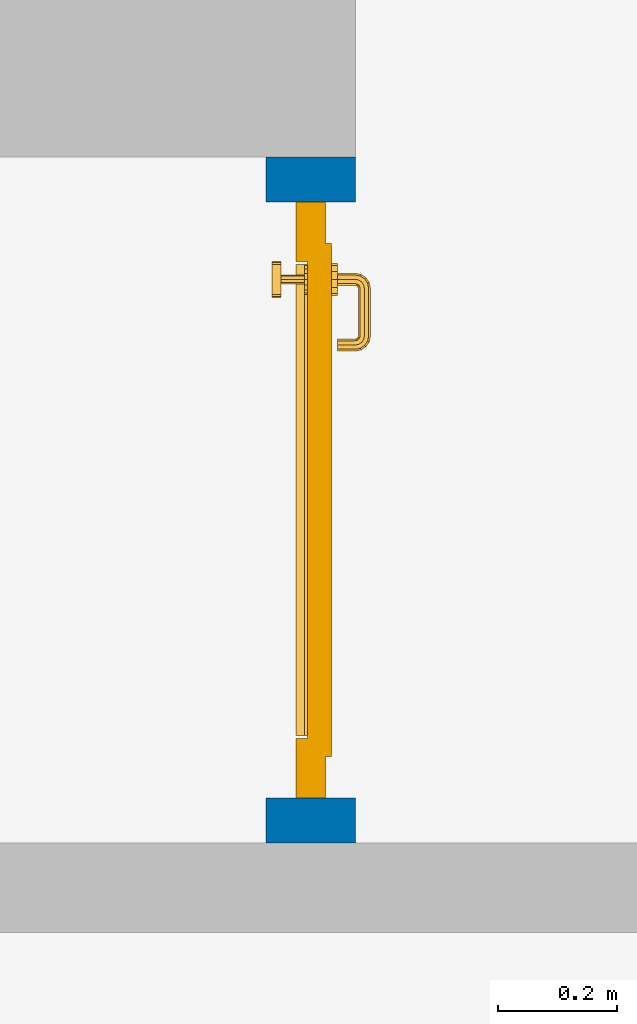
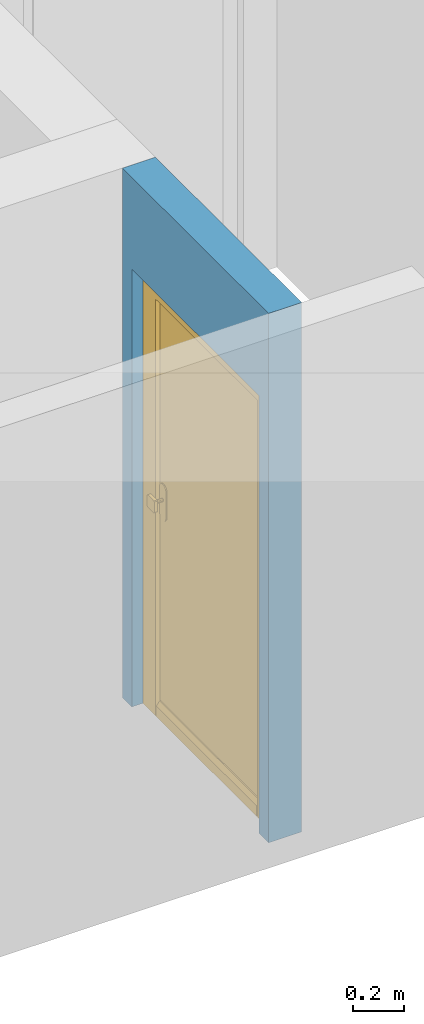
# One storey, part 4 of 54: 1 door, 1 wall, 1 opening.
"""IFC4 building model written with IfcOpenShell, lengths in metres."""

from ifc_helpers import new_model, entity, si_unit, converted_unit, derived_unit, direction, frame, origin_with_axes, place, context, subcontext, project, spatial, polygons, source, transform, mapped, material, type_object, element, fill, save


model = new_model("IFC4")

# Units and contexts
model_context = context("Model", 3, precision=1e-05, world=origin_with_axes(), true_north=direction((0.0, 1.0)))
body_context = subcontext(model_context, "Body", "Model", "MODEL_VIEW")
ifc_project = project(units=[si_unit("LENGTHUNIT", "METRE"), si_unit("AREAUNIT", "SQUARE_METRE"), si_unit("VOLUMEUNIT", "CUBIC_METRE"), converted_unit("PLANEANGLEUNIT", "DEGREE", entity("IfcPlaneAngleMeasure", 0.0174532925199), si_unit("PLANEANGLEUNIT", "RADIAN"), dimensions=[0, 0, 0, 0, 0, 0, 0]), converted_unit("TIMEUNIT", "Year", entity("IfcTimeMeasure", 31556926.0), si_unit("TIMEUNIT", "SECOND"), dimensions=[0, 0, 1, 0, 0, 0, 0]), si_unit("MASSUNIT", "GRAM", prefix="KILO"), si_unit("THERMODYNAMICTEMPERATUREUNIT", "DEGREE_CELSIUS"), si_unit("LUMINOUSINTENSITYUNIT", "LUMEN"), si_unit("ENERGYUNIT", "JOULE", prefix="MEGA"), derived_unit("THERMALCONDUCTANCEUNIT", [(si_unit("POWERUNIT", "WATT"), 1), (si_unit("LENGTHUNIT", "METRE"), -1), (si_unit("THERMODYNAMICTEMPERATUREUNIT", "KELVIN"), -1)]), derived_unit("SPECIFICHEATCAPACITYUNIT", [(si_unit("ENERGYUNIT", "JOULE"), 1), (si_unit("MASSUNIT", "GRAM", prefix="KILO"), -1), (si_unit("THERMODYNAMICTEMPERATUREUNIT", "KELVIN"), -1)]), derived_unit("MASSDENSITYUNIT", [(si_unit("MASSUNIT", "GRAM", prefix="KILO"), 1), (si_unit("VOLUMEUNIT", "CUBIC_METRE"), -1)])], contexts=[model_context])

# Site, building, storey
site_placement = place(None, origin_with_axes())
site = spatial("IfcSite", under=ifc_project, at=site_placement, CompositionType="ELEMENT")
building_placement = place(site_placement, origin_with_axes())
building = spatial("IfcBuilding", under=site, at=building_placement, CompositionType="ELEMENT")
storey_placement = place(building_placement, frame((0.0, 0.0, 9.18), z_axis=(0.0, 0.0, 1.0), x_axis=(1.0, 0.0, 0.0)))
storey = spatial("IfcBuildingStorey", under=building, at=storey_placement, Name="3. Geschoss", CompositionType="ELEMENT", Elevation=9.18)

# Wall, opening, door
ifc_material = material()
wall_type = type_object("IfcWallType", Name="150", PredefinedType="NOTDEFINED")
wall_placement = place(storey_placement, frame((2.8378006196, -4.12881223104, 0.0), z_axis=(0.0, 0.0, 1.0), x_axis=(0.0, 1.0, 0.0)))
wall = element("IfcWall", 1, at=wall_placement, inside=storey, type_object=wall_type, material=ifc_material, Name="Wand-002", PredefinedType="NOTDEFINED", context=body_context, shape_type="Tessellation", body=[
    polygons([(0.225, 0.0, 0.0), (0.225, 0.0, 2.1), (1.225, 0.0, 2.1), (1.225, 0.0, 0.0), (1.3, 0.0, 0.0), (1.3, 0.0, 2.54), (0.15, 0.0, 2.54), (0.15, 0.0, 0.0), (0.225, 0.1, 0.0), (0.225, 0.15, 0.0), (0.225, 0.15, 2.1), (1.225, 0.15, 2.1), (1.225, 0.1, 0.0), (1.225, 0.15, 0.0), (1.3, 0.15, 0.0), (1.3, 0.15, 2.54), (0.15, 0.15, 2.54), (0.15, 0.15, 0.0)], [[[1, 2, 3, 4, 5, 6, 7, 8]], [[2, 1, 9, 10, 11]], [[3, 2, 11, 12]], [[13, 4, 3, 12, 14]], [[4, 13, 14, 15, 5]], [[6, 5, 15, 16]], [[6, 16, 17, 7]], [[17, 18, 8, 7]], [[9, 1, 8, 18, 10]], [[15, 14, 12, 11, 10, 18, 17, 16]]], closed=True),
])
opening_placement = place(wall_placement, frame((0.725, 0.0, 0.0), z_axis=(0.0, 0.0, 1.0), x_axis=(1.0, 0.0, 0.0)))
opening = element("IfcOpeningElement", 2, at=opening_placement, cuts=wall, context=body_context, identifier="Reference", shape_type="Tessellation", body=[
    polygons([(-0.5, 0.1, 0.0), (-0.5, 0.1, 2.1), (-0.5, 0.151, 2.1), (-0.5, 0.151, 0.0), (-0.5, -0.001, 0.0), (-0.5, -0.001, 2.1), (0.5, 0.1, 2.1), (0.5, 0.151, 2.1), (0.5, -0.001, 2.1), (0.5, 0.151, 0.0), (0.5, 0.1, 0.0), (0.5, -0.001, 0.0)], [[[1, 2, 3, 4]], [[2, 1, 5, 6]], [[7, 8, 3, 2, 6, 9]], [[8, 10, 4, 3]], [[1, 4, 10, 11, 12, 5]], [[6, 5, 12, 9]], [[7, 11, 10, 8]], [[11, 7, 9, 12]]], closed=True),
])
door_type = type_object("IfcDoorType", Name="Eingang 01 1-Fl 26", OperationType="SINGLE_SWING_RIGHT", PredefinedType="DOOR")
shared_shape = source(origin_with_axes(), body_context, "Body", "Tessellation", [
    polygons([(0.5, -0.05, 0.0), (0.5, -0.03, 0.0), (0.5, -0.03, 2.1), (0.5, -0.05, 2.1), (0.4, -0.05, 0.0), (0.4, -0.03, 0.0), (0.4, -0.03, 2.0), (0.1301, -0.03, 2.0), (0.0001, -0.03, 2.0), (-0.4, -0.03, 2.0), (-0.4, -0.03, 0.0), (-0.5, -0.03, 0.0), (-0.5, -0.03, 2.1), (-0.5, -0.05, 2.1), (-0.5, -0.05, 0.0), (-0.4, -0.05, 0.0), (-0.4, -0.05, 2.0), (0.0001, -0.05, 2.0), (0.1301, -0.05, 2.0), (0.4, -0.05, 2.0)], [[[1, 2, 3, 4]], [[5, 6, 2, 1]], [[2, 6, 7, 8, 9, 10, 11, 12, 13, 3]], [[4, 3, 13, 14]], [[1, 4, 14, 15, 16, 17, 18, 19, 20, 5]], [[20, 7, 6, 5]], [[19, 8, 7, 20]], [[18, 9, 8, 19]], [[17, 10, 9, 18]], [[16, 11, 10, 17]], [[15, 12, 11, 16]], [[14, 13, 12, 15]]], closed=True),
    polygons([(0.5, -0.03, 0.0), (0.5, 0.0, 0.0), (0.5, 0.0, 2.1), (0.5, -0.03, 2.1), (0.43, -0.03, 0.0), (0.43, 0.0, 0.0), (0.43, 0.0, 2.03), (0.1001, 0.0, 2.03), (0.0301, 0.0, 2.03), (-0.43, 0.0, 2.03), (-0.43, 0.0, 0.0), (-0.5, 0.0, 0.0), (-0.5, 0.0, 2.1), (-0.5, -0.03, 2.1), (-0.5, -0.03, 0.0), (-0.43, -0.03, 0.0), (-0.43, -0.03, 2.03), (0.0301, -0.03, 2.03), (0.1001, -0.03, 2.03), (0.43, -0.03, 2.03)], [[[1, 2, 3, 4]], [[5, 6, 2, 1]], [[2, 6, 7, 8, 9, 10, 11, 12, 13, 3]], [[4, 3, 13, 14]], [[1, 4, 14, 15, 16, 17, 18, 19, 20, 5]], [[20, 7, 6, 5]], [[19, 8, 7, 20]], [[18, 9, 8, 19]], [[17, 10, 9, 18]], [[16, 11, 10, 17]], [[15, 12, 11, 16]], [[14, 13, 12, 15]]], closed=True),
    polygons([(0.43, 0.01, 0.0), (-0.43, 0.01, 0.0), (-0.43, 0.01, 2.03), (0.43, 0.01, 2.03), (0.43, -0.03, 0.0), (-0.43, -0.03, 0.0), (-0.43, -0.03, 2.03), (0.43, -0.03, 2.03)], [[[1, 2, 3, 4]], [[2, 1, 5, 6]], [[3, 2, 6, 7]], [[4, 3, 7, 8]], [[1, 4, 8, 5]], [[6, 5, 8, 7]]], closed=True),
    polygons([(0.395, -0.05, 0.0), (0.395, -0.05, 0.05), (-0.395, -0.05, 0.05), (-0.395, -0.05, 0.0), (0.395, -0.03, 0.0), (0.395, -0.03, 0.07), (0.395, -0.035, 0.07), (-0.395, -0.035, 0.07), (-0.395, -0.03, 0.07), (-0.395, -0.03, 0.0)], [[[1, 2, 3, 4]], [[1, 5, 6, 7, 2]], [[2, 7, 8, 3]], [[4, 3, 8, 9, 10]], [[5, 1, 4, 10]], [[6, 5, 10, 9]], [[7, 6, 9, 8]]], closed=True),
    polygons([(-0.3835, 0.02, 1.0733826859), (-0.3835, 0.0199, 1.0733826859), (-0.37, 0.0199, 1.077), (-0.37, 0.02, 1.077), (-0.393382685902, 0.02, 1.0635), (-0.393382685902, 0.0199, 1.0635), (-0.3835, 0.0101, 1.0733826859), (-0.37, 0.0101, 1.077), (-0.3565, 0.0199, 1.0733826859), (-0.3565, 0.02, 1.0733826859), (-0.346617314098, 0.02, 1.0635), (-0.343, 0.02, 1.05), (-0.346617314098, 0.02, 1.0365), (-0.3565, 0.02, 1.0266173141), (-0.37, 0.02, 1.023), (-0.3835, 0.02, 1.0266173141), (-0.393382685902, 0.02, 1.0365), (-0.397, 0.02, 1.05), (-0.397, 0.0199, 1.05), (-0.393382685902, 0.0101, 1.0635), (-0.3835, 0.01, 1.0733826859), (-0.37, 0.01, 1.077), (-0.3565, 0.0101, 1.0733826859), (-0.346617314098, 0.0199, 1.0635), (-0.343, 0.0199, 1.05), (-0.346617314098, 0.0199, 1.0365), (-0.3565, 0.0199, 1.0266173141), (-0.37, 0.0199, 1.023), (-0.3835, 0.0199, 1.0266173141), (-0.393382685902, 0.0199, 1.0365), (-0.397, 0.0101, 1.05), (-0.393382685902, 0.01, 1.0635), (-0.397, 0.01, 1.05), (-0.393382685902, 0.01, 1.0365), (-0.3835, 0.01, 1.0266173141), (-0.37, 0.01, 1.023), (-0.3565, 0.01, 1.0266173141), (-0.346617314098, 0.01, 1.0365), (-0.343, 0.01, 1.05), (-0.346617314098, 0.01, 1.0635), (-0.3565, 0.01, 1.0733826859), (-0.346617314098, 0.0101, 1.0635), (-0.343, 0.0101, 1.05), (-0.346617314098, 0.0101, 1.0365), (-0.3565, 0.0101, 1.0266173141), (-0.37, 0.0101, 1.023), (-0.3835, 0.0101, 1.0266173141), (-0.393382685902, 0.0101, 1.0365)], [[[1, 2, 3, 4]], [[5, 6, 2, 1]], [[2, 7, 8, 3]], [[4, 3, 9, 10]], [[4, 10, 11, 12, 13, 14, 15, 16, 17, 18, 5, 1]], [[18, 19, 6, 5]], [[6, 20, 7, 2]], [[7, 21, 22, 8]], [[3, 8, 23, 9]], [[10, 9, 24, 11]], [[11, 24, 25, 12]], [[12, 25, 26, 13]], [[13, 26, 27, 14]], [[14, 27, 28, 15]], [[15, 28, 29, 16]], [[16, 29, 30, 17]], [[17, 30, 19, 18]], [[19, 31, 20, 6]], [[20, 32, 21, 7]], [[22, 21, 32, 33, 34, 35, 36, 37, 38, 39, 40, 41]], [[8, 22, 41, 23]], [[9, 23, 42, 24]], [[24, 42, 43, 25]], [[25, 43, 44, 26]], [[26, 44, 45, 27]], [[27, 45, 46, 28]], [[28, 46, 47, 29]], [[29, 47, 48, 30]], [[30, 48, 31, 19]], [[31, 33, 32, 20]], [[48, 34, 33, 31]], [[47, 35, 34, 48]], [[46, 36, 35, 47]], [[45, 37, 36, 46]], [[44, 38, 37, 45]], [[43, 39, 38, 44]], [[42, 40, 39, 43]], [[23, 41, 40, 42]]], closed=True),
    polygons([(-0.362532169224, 0.019, 0.959692280177), (-0.365, 0.019, 0.9544), (-0.365, 0.019, 0.952886751346), (-0.347569942042, 0.019, 0.96295), (-0.35705, 0.019, 0.972430057958), (-0.363279754556, 0.019, 0.961639806549), (-0.362532169224, 0.02, 0.959692280177), (-0.365, 0.02, 0.9544), (-0.365, 0.02, 0.952886751346), (-0.365, 0.02, 0.95), (-0.365, 0.02, 0.947113248654), (-0.365, 0.02, 0.941339745962), (-0.365, 0.02, 0.9375), (-0.365, 0.019, 0.9375), (-0.365, 0.019, 0.941339745962), (-0.365, 0.019, 0.947113248654), (-0.365, 0.019, 0.95), (-0.3441, 0.019, 0.95), (-0.347483339502, 0.019, 0.963), (-0.357, 0.019, 0.972516660498), (-0.364624817685, 0.019, 0.965143815798), (-0.37, 0.019, 0.9759), (-0.37, 0.019, 0.967425445323), (-0.364624817685, 0.02, 0.965143815798), (-0.363279754556, 0.02, 0.961639806549), (-0.35655, 0.02, 0.973296083362), (-0.346703916638, 0.02, 0.96345), (-0.3431, 0.02, 0.95), (-0.346703916638, 0.02, 0.93655), (-0.35655, 0.02, 0.926703916638), (-0.37, 0.02, 0.9231), (-0.37, 0.02, 0.9325), (-0.366464466094, 0.02, 0.933964466094), (-0.366464466094, 0.019, 0.933964466094), (-0.35705, 0.019, 0.927569942042), (-0.37, 0.019, 0.9325), (-0.37, 0.019, 0.9241), (-0.347569942042, 0.019, 0.93705), (-0.344, 0.019, 0.95), (-0.347483339502, 0.0189, 0.963), (-0.357, 0.0189, 0.972516660498), (-0.37, 0.019, 0.976), (-0.375375182315, 0.019, 0.965143815798), (-0.38295, 0.019, 0.972430057958), (-0.376720245444, 0.019, 0.961639806549), (-0.37, 0.02, 0.967425445323), (-0.37, 0.02, 0.9769), (-0.346617314098, 0.02, 0.9635), (-0.3565, 0.02, 0.973382685902), (-0.343, 0.02, 0.95), (-0.346617314098, 0.02, 0.9365), (-0.3565, 0.02, 0.926617314098), (-0.38345, 0.02, 0.926703916638), (-0.375, 0.02, 0.941339745962), (-0.375, 0.02, 0.9375), (-0.373535533906, 0.02, 0.933964466094), (-0.37, 0.02, 0.923), (-0.373535533906, 0.019, 0.933964466094), (-0.375, 0.019, 0.9375), (-0.375, 0.019, 0.941339745962), (-0.38295, 0.019, 0.927569942042), (-0.37, 0.019, 0.924), (-0.357, 0.019, 0.927483339502), (-0.347483339502, 0.019, 0.937), (-0.344, 0.0189, 0.95), (-0.347483339502, 0.0101, 0.963), (-0.357, 0.0101, 0.972516660498), (-0.37, 0.0189, 0.976), (-0.383, 0.019, 0.972516660498), (-0.375375182315, 0.02, 0.965143815798), (-0.377467830776, 0.019, 0.959692280177), (-0.392430057958, 0.019, 0.96295), (-0.375, 0.019, 0.952886751346), (-0.375, 0.019, 0.9544), (-0.377467830776, 0.02, 0.959692280177), (-0.376720245444, 0.02, 0.961639806549), (-0.38345, 0.02, 0.973296083362), (-0.37, 0.02, 0.977), (-0.346617314098, 0.0199, 0.9635), (-0.3565, 0.0199, 0.973382685902), (-0.343, 0.0199, 0.95), (-0.346617314098, 0.0199, 0.9365), (-0.3565, 0.0199, 0.926617314098), (-0.393296083362, 0.02, 0.93655), (-0.375, 0.02, 0.947113248654), (-0.375, 0.02, 0.9544), (-0.375, 0.019, 0.95), (-0.375, 0.019, 0.947113248654), (-0.375, 0.02, 0.95), (-0.375, 0.02, 0.952886751346), (-0.3835, 0.02, 0.926617314098), (-0.37, 0.0199, 0.923), (-0.392430057958, 0.019, 0.93705), (-0.383, 0.019, 0.927483339502), (-0.37, 0.0189, 0.924), (-0.357, 0.0189, 0.927483339502), (-0.347483339502, 0.0189, 0.937), (-0.344, 0.0101, 0.95), (-0.347483339502, 0.01, 0.963), (-0.357, 0.01, 0.972516660498), (-0.37, 0.0101, 0.976), (-0.383, 0.0189, 0.972516660498), (-0.392516660498, 0.019, 0.963), (-0.3959, 0.019, 0.95), (-0.393296083362, 0.02, 0.96345), (-0.3835, 0.02, 0.973382685902), (-0.37, 0.0199, 0.977), (-0.346617314098, 0.0101, 0.9635), (-0.3565, 0.0101, 0.973382685902), (-0.343, 0.0101, 0.95), (-0.346617314098, 0.0101, 0.9365), (-0.3565, 0.0101, 0.926617314098), (-0.393382685902, 0.02, 0.9365), (-0.3969, 0.02, 0.95), (-0.3835, 0.0199, 0.926617314098), (-0.37, 0.0101, 0.923), (-0.392516660498, 0.019, 0.937), (-0.383, 0.0189, 0.927483339502), (-0.37, 0.0101, 0.924), (-0.357, 0.0101, 0.927483339502), (-0.347483339502, 0.0101, 0.937), (-0.344, 0.01, 0.95), (-0.347396736961, 0.01, 0.96305), (-0.35695, 0.01, 0.972603263039), (-0.37, 0.01, 0.976), (-0.383, 0.0101, 0.972516660498), (-0.392516660498, 0.0189, 0.963), (-0.396, 0.019, 0.95), (-0.393382685902, 0.02, 0.9635), (-0.3835, 0.0199, 0.973382685902), (-0.37, 0.0101, 0.977), (-0.346617314098, 0.01, 0.9635), (-0.3565, 0.01, 0.973382685902), (-0.343, 0.01, 0.95), (-0.346617314098, 0.01, 0.9365), (-0.3565, 0.01, 0.926617314098), (-0.397, 0.02, 0.95), (-0.393382685902, 0.0199, 0.9365), (-0.3835, 0.0101, 0.926617314098), (-0.37, 0.01, 0.923), (-0.392516660498, 0.0189, 0.937), (-0.383, 0.0101, 0.927483339502), (-0.37, 0.01, 0.924), (-0.357, 0.01, 0.927483339502), (-0.347483339502, 0.01, 0.937), (-0.3439, 0.01, 0.95), (-0.346703916638, 0.01, 0.96345), (-0.35655, 0.01, 0.973296083362), (-0.37, 0.01, 0.9761), (-0.383, 0.01, 0.972516660498), (-0.392516660498, 0.0101, 0.963), (-0.396, 0.0189, 0.95), (-0.393382685902, 0.0199, 0.9635), (-0.3835, 0.0101, 0.973382685902), (-0.37, 0.01, 0.977), (-0.3431, 0.01, 0.95), (-0.346703916638, 0.01, 0.93655), (-0.35655, 0.01, 0.926703916638), (-0.397, 0.0199, 0.95), (-0.393382685902, 0.0101, 0.9365), (-0.3835, 0.01, 0.926617314098), (-0.37, 0.01, 0.9231), (-0.392516660498, 0.0101, 0.937), (-0.383, 0.01, 0.927483339502), (-0.37, 0.01, 0.9239), (-0.35695, 0.01, 0.927396736961), (-0.347396736961, 0.01, 0.93695), (-0.37, 0.01, 0.9769), (-0.38305, 0.01, 0.972603263039), (-0.392516660498, 0.01, 0.963), (-0.396, 0.0101, 0.95), (-0.393382685902, 0.0101, 0.9635), (-0.3835, 0.01, 0.973382685902), (-0.397, 0.0101, 0.95), (-0.393382685902, 0.01, 0.9365), (-0.38345, 0.01, 0.926703916638), (-0.392516660498, 0.01, 0.937), (-0.38305, 0.01, 0.927396736961), (-0.38345, 0.01, 0.973296083362), (-0.392603263039, 0.01, 0.96305), (-0.396, 0.01, 0.95), (-0.393382685902, 0.01, 0.9635), (-0.397, 0.01, 0.95), (-0.393296083362, 0.01, 0.93655), (-0.392603263039, 0.01, 0.93695), (-0.393296083362, 0.01, 0.96345), (-0.3961, 0.01, 0.95), (-0.3969, 0.01, 0.95)], [[[1, 2, 3, 4, 5, 6]], [[2, 1, 7, 8]], [[2, 8, 9, 10, 11, 12, 13, 14, 15, 16, 17, 3]], [[17, 18, 4, 3]], [[4, 19, 20, 5]], [[21, 6, 5, 22, 23]], [[1, 6, 21, 24, 25, 7]], [[7, 25, 26, 27, 9, 8]], [[9, 27, 28, 10]], [[10, 28, 29, 11]], [[11, 29, 30, 12]], [[31, 32, 33, 13, 12, 30]], [[14, 13, 33, 34]], [[35, 15, 14, 34, 36, 37]], [[15, 35, 38, 16]], [[16, 38, 18, 17]], [[18, 39, 19, 4]], [[19, 40, 41, 20]], [[5, 20, 42, 22]], [[43, 23, 22, 44, 45]], [[21, 23, 46, 24]], [[24, 46, 47, 26, 25]], [[48, 27, 26, 49]], [[50, 28, 27, 48]], [[51, 29, 28, 50]], [[52, 30, 29, 51]], [[53, 54, 55, 56, 32, 31]], [[34, 33, 32, 36]], [[57, 31, 30, 52]], [[37, 36, 58, 59, 60, 61]], [[37, 62, 63, 35]], [[35, 63, 64, 38]], [[38, 64, 39, 18]], [[39, 65, 40, 19]], [[40, 66, 67, 41]], [[20, 41, 68, 42]], [[22, 42, 69, 44]], [[23, 43, 70, 46]], [[71, 45, 44, 72, 73, 74]], [[43, 45, 71, 75, 76, 70]], [[70, 76, 77, 47, 46]], [[49, 26, 47, 78]], [[79, 48, 49, 80]], [[81, 50, 48, 79]], [[82, 51, 50, 81]], [[83, 52, 51, 82]], [[54, 53, 84, 85]], [[86, 74, 73, 87, 88, 60, 59, 55, 54, 85, 89, 90]], [[58, 56, 55, 59]], [[36, 32, 56, 58]], [[91, 53, 31, 57]], [[92, 57, 52, 83]], [[88, 93, 61, 60]], [[61, 94, 62, 37]], [[62, 95, 96, 63]], [[63, 96, 97, 64]], [[64, 97, 65, 39]], [[65, 98, 66, 40]], [[66, 99, 100, 67]], [[41, 67, 101, 68]], [[42, 68, 102, 69]], [[44, 69, 103, 72]], [[73, 72, 104, 87]], [[71, 74, 86, 75]], [[75, 86, 90, 105, 77, 76]], [[78, 47, 77, 106]], [[80, 49, 78, 107]], [[108, 79, 80, 109]], [[110, 81, 79, 108]], [[111, 82, 81, 110]], [[112, 83, 82, 111]], [[113, 84, 53, 91]], [[85, 84, 114, 89]], [[87, 104, 93, 88]], [[89, 114, 105, 90]], [[115, 91, 57, 92]], [[116, 92, 83, 112]], [[93, 117, 94, 61]], [[94, 118, 95, 62]], [[95, 119, 120, 96]], [[96, 120, 121, 97]], [[97, 121, 98, 65]], [[98, 122, 99, 66]], [[99, 123, 124, 100]], [[67, 100, 125, 101]], [[68, 101, 126, 102]], [[69, 102, 127, 103]], [[72, 103, 128, 104]], [[106, 77, 105, 129]], [[107, 78, 106, 130]], [[109, 80, 107, 131]], [[132, 108, 109, 133]], [[134, 110, 108, 132]], [[135, 111, 110, 134]], [[136, 112, 111, 135]], [[137, 114, 84, 113]], [[138, 113, 91, 115]], [[104, 128, 117, 93]], [[129, 105, 114, 137]], [[139, 115, 92, 116]], [[140, 116, 112, 136]], [[117, 141, 118, 94]], [[118, 142, 119, 95]], [[119, 143, 144, 120]], [[120, 144, 145, 121]], [[121, 145, 122, 98]], [[122, 146, 123, 99]], [[123, 147, 148, 124]], [[100, 124, 149, 125]], [[101, 125, 150, 126]], [[102, 126, 151, 127]], [[103, 127, 152, 128]], [[130, 106, 129, 153]], [[131, 107, 130, 154]], [[133, 109, 131, 155]], [[147, 132, 133, 148]], [[156, 134, 132, 147]], [[157, 135, 134, 156]], [[158, 136, 135, 157]], [[159, 137, 113, 138]], [[160, 138, 115, 139]], [[128, 152, 141, 117]], [[153, 129, 137, 159]], [[161, 139, 116, 140]], [[162, 140, 136, 158]], [[141, 163, 142, 118]], [[142, 164, 143, 119]], [[143, 165, 166, 144]], [[144, 166, 167, 145]], [[145, 167, 146, 122]], [[146, 156, 147, 123]], [[124, 148, 168, 149]], [[125, 149, 169, 150]], [[126, 150, 170, 151]], [[127, 151, 171, 152]], [[154, 130, 153, 172]], [[155, 131, 154, 173]], [[148, 133, 155, 168]], [[167, 157, 156, 146]], [[166, 158, 157, 167]], [[174, 159, 138, 160]], [[175, 160, 139, 161]], [[152, 171, 163, 141]], [[172, 153, 159, 174]], [[176, 161, 140, 162]], [[165, 162, 158, 166]], [[163, 177, 164, 142]], [[164, 178, 165, 143]], [[149, 168, 179, 169]], [[150, 169, 180, 170]], [[151, 170, 181, 171]], [[173, 154, 172, 182]], [[168, 155, 173, 179]], [[183, 174, 160, 175]], [[184, 175, 161, 176]], [[171, 181, 177, 163]], [[182, 172, 174, 183]], [[178, 176, 162, 165]], [[177, 185, 178, 164]], [[169, 179, 186, 180]], [[170, 180, 187, 181]], [[179, 173, 182, 186]], [[188, 183, 175, 184]], [[185, 184, 176, 178]], [[181, 187, 185, 177]], [[186, 182, 183, 188]], [[180, 186, 188, 187]], [[187, 188, 184, 185]]], closed=True),
    polygons([(-0.38, 0.02, 1.05), (-0.38, 0.0509849140336, 1.05), (-0.377071067812, 0.050696439392, 1.04292893219), (-0.377071067812, 0.02, 1.04292893219), (-0.377071067812, 0.02, 1.05707106781), (-0.377071067812, 0.050696439392, 1.05707106781), (-0.378277987014, 0.0596420579258, 1.05), (-0.375518993221, 0.0584992452783, 1.04292893219), (-0.37, 0.05, 1.04), (-0.37, 0.02, 1.04), (-0.37, 0.02, 1.06), (-0.37, 0.05, 1.06), (-0.375518993221, 0.0584992452783, 1.05707106781), (-0.372816199938, 0.0678161999379, 1.05), (-0.370704557509, 0.0657045575088, 1.04292893219), (-0.368858192988, 0.0557402514855, 1.04), (-0.362928932188, 0.049303560608, 1.04292893219), (-0.362928932188, 0.02, 1.04292893219), (-0.362928932188, 0.02, 1.05707106781), (-0.362928932188, 0.049303560608, 1.05707106781), (-0.368858192988, 0.0557402514855, 1.06), (-0.370704557509, 0.0657045575088, 1.05707106781), (-0.364642057926, 0.0732779870137, 1.05), (-0.363499245278, 0.0705189932208, 1.04292893219), (-0.365606601718, 0.0606066017178, 1.04), (-0.362197392755, 0.0529812576926, 1.04292893219), (-0.36, 0.0490150859664, 1.05), (-0.36, 0.02, 1.05), (-0.362197392755, 0.0529812576926, 1.05707106781), (-0.365606601718, 0.0606066017178, 1.06), (-0.363499245278, 0.0705189932208, 1.05707106781), (-0.355984914034, 0.075, 1.05), (-0.355696439392, 0.0720710678119, 1.04292893219), (-0.360740251485, 0.0638581929877, 1.04), (-0.360508645927, 0.0555086459268, 1.04292893219), (-0.359438398962, 0.0518384450452, 1.05), (-0.360508645927, 0.0555086459268, 1.05707106781), (-0.360740251485, 0.0638581929877, 1.06), (-0.355696439392, 0.0720710678119, 1.05707106781), (-0.274015085966, 0.075, 1.05), (-0.274303560608, 0.0720710678119, 1.04292893219), (-0.355, 0.065, 1.04), (-0.357981257693, 0.0571973927545, 1.04292893219), (-0.358397003498, 0.0533970034977, 1.05), (-0.357981257693, 0.0571973927545, 1.05707106781), (-0.355, 0.065, 1.06), (-0.274303560608, 0.0720710678119, 1.05707106781), (-0.265357942074, 0.0732779870137, 1.05), (-0.266500754722, 0.0705189932208, 1.04292893219), (-0.275, 0.065, 1.04), (-0.354303560608, 0.0579289321881, 1.04292893219), (-0.356838445045, 0.0544383989617, 1.05), (-0.354303560608, 0.0579289321881, 1.05707106781), (-0.275, 0.065, 1.06), (-0.266500754722, 0.0705189932208, 1.05707106781), (-0.257183800062, 0.0678161999379, 1.05), (-0.259295442491, 0.0657045575088, 1.04292893219), (-0.269259748515, 0.0638581929877, 1.04), (-0.275696439392, 0.0579289321881, 1.04292893219), (-0.354015085966, 0.055, 1.05), (-0.275696439392, 0.0579289321881, 1.05707106781), (-0.269259748515, 0.0638581929877, 1.06), (-0.259295442491, 0.0657045575088, 1.05707106781), (-0.251722012986, 0.0596420579258, 1.05), (-0.254481006779, 0.0584992452783, 1.04292893219), (-0.264393398282, 0.0606066017178, 1.04), (-0.272018742307, 0.0571973927545, 1.04292893219), (-0.275984914034, 0.055, 1.05), (-0.272018742307, 0.0571973927545, 1.05707106781), (-0.264393398282, 0.0606066017178, 1.06), (-0.254481006779, 0.0584992452783, 1.05707106781), (-0.25, 0.0509849140336, 1.05), (-0.252928932188, 0.050696439392, 1.04292893219), (-0.261141807012, 0.0557402514855, 1.04), (-0.269491354073, 0.0555086459268, 1.04292893219), (-0.273161554955, 0.0544383989617, 1.05), (-0.269491354073, 0.0555086459268, 1.05707106781), (-0.261141807012, 0.0557402514855, 1.06), (-0.252928932188, 0.050696439392, 1.05707106781), (-0.25, 0.02, 1.05), (-0.252928932188, 0.02, 1.04292893219), (-0.26, 0.05, 1.04), (-0.267802607245, 0.0529812576926, 1.04292893219), (-0.271602996502, 0.0533970034977, 1.05), (-0.267802607245, 0.0529812576926, 1.05707106781), (-0.26, 0.05, 1.06), (-0.252928932188, 0.02, 1.05707106781), (-0.26, 0.02, 1.06), (-0.267071067812, 0.02, 1.05707106781), (-0.27, 0.02, 1.05), (-0.267071067812, 0.02, 1.04292893219), (-0.26, 0.02, 1.04), (-0.267071067812, 0.049303560608, 1.04292893219), (-0.270561601038, 0.0518384450452, 1.05), (-0.267071067812, 0.049303560608, 1.05707106781), (-0.27, 0.0490150859664, 1.05)], [[[1, 2, 3, 4]], [[5, 6, 2, 1]], [[2, 7, 8, 3]], [[4, 3, 9, 10]], [[11, 12, 6, 5]], [[6, 13, 7, 2]], [[7, 14, 15, 8]], [[3, 8, 16, 9]], [[10, 9, 17, 18]], [[19, 20, 12, 11]], [[12, 21, 13, 6]], [[13, 22, 14, 7]], [[14, 23, 24, 15]], [[8, 15, 25, 16]], [[9, 16, 26, 17]], [[18, 17, 27, 28]], [[28, 27, 20, 19]], [[20, 29, 21, 12]], [[21, 30, 22, 13]], [[22, 31, 23, 14]], [[23, 32, 33, 24]], [[15, 24, 34, 25]], [[16, 25, 35, 26]], [[17, 26, 36, 27]], [[27, 36, 29, 20]], [[29, 37, 30, 21]], [[30, 38, 31, 22]], [[31, 39, 32, 23]], [[32, 40, 41, 33]], [[24, 33, 42, 34]], [[25, 34, 43, 35]], [[26, 35, 44, 36]], [[36, 44, 37, 29]], [[37, 45, 38, 30]], [[38, 46, 39, 31]], [[39, 47, 40, 32]], [[40, 48, 49, 41]], [[33, 41, 50, 42]], [[34, 42, 51, 43]], [[35, 43, 52, 44]], [[44, 52, 45, 37]], [[45, 53, 46, 38]], [[46, 54, 47, 39]], [[47, 55, 48, 40]], [[48, 56, 57, 49]], [[41, 49, 58, 50]], [[42, 50, 59, 51]], [[43, 51, 60, 52]], [[52, 60, 53, 45]], [[53, 61, 54, 46]], [[54, 62, 55, 47]], [[55, 63, 56, 48]], [[56, 64, 65, 57]], [[49, 57, 66, 58]], [[50, 58, 67, 59]], [[51, 59, 68, 60]], [[60, 68, 61, 53]], [[61, 69, 62, 54]], [[62, 70, 63, 55]], [[63, 71, 64, 56]], [[64, 72, 73, 65]], [[57, 65, 74, 66]], [[58, 66, 75, 67]], [[59, 67, 76, 68]], [[68, 76, 69, 61]], [[69, 77, 70, 62]], [[70, 78, 71, 63]], [[71, 79, 72, 64]], [[72, 80, 81, 73]], [[65, 73, 82, 74]], [[66, 74, 83, 75]], [[67, 75, 84, 76]], [[76, 84, 77, 69]], [[77, 85, 78, 70]], [[78, 86, 79, 71]], [[79, 87, 80, 72]], [[80, 87, 88, 89, 90, 91, 92, 81]], [[73, 81, 92, 82]], [[74, 82, 93, 83]], [[75, 83, 94, 84]], [[84, 94, 85, 77]], [[85, 95, 86, 78]], [[86, 88, 87, 79]], [[95, 89, 88, 86]], [[96, 90, 89, 95]], [[93, 91, 90, 96]], [[82, 92, 91, 93]], [[83, 93, 96, 94]], [[94, 96, 95, 85]]], closed=False),
    polygons([(-0.364696699141, -0.035, 1.04469669914), (-0.37, -0.035, 1.0425), (-0.375303300859, -0.035, 1.04469669914), (-0.3775, -0.035, 1.05), (-0.375303300859, -0.035, 1.05530330086), (-0.37, -0.035, 1.0575), (-0.364696699141, -0.035, 1.05530330086), (-0.3625, -0.035, 1.05), (-0.364696699141, -0.075, 1.04469669914), (-0.37, -0.075, 1.0425), (-0.375303300859, -0.075, 1.04469669914), (-0.3775, -0.075, 1.05), (-0.375303300859, -0.075, 1.05530330086), (-0.37, -0.075, 1.0575), (-0.364696699141, -0.075, 1.05530330086), (-0.3625, -0.075, 1.05)], [[[1, 2, 3, 4, 5, 6, 7, 8]], [[2, 1, 9, 10]], [[3, 2, 10, 11]], [[4, 3, 11, 12]], [[5, 4, 12, 13]], [[6, 5, 13, 14]], [[7, 6, 14, 15]], [[8, 7, 15, 16]], [[1, 8, 16, 9]], [[9, 16, 15, 14, 13, 12, 11, 10]]], closed=True),
    polygons([(-0.395, -0.03, 0.975), (-0.393096988313, -0.03, 0.965432914191), (-0.393096988313, -0.035, 0.965432914191), (-0.395, -0.035, 0.975), (-0.395, -0.03, 1.1), (-0.393096988313, -0.03, 1.10956708581), (-0.38767766953, -0.03, 1.11767766953), (-0.379567085809, -0.03, 1.12309698831), (-0.37, -0.03, 1.125), (-0.360432914191, -0.03, 1.12309698831), (-0.35232233047, -0.03, 1.11767766953), (-0.346903011687, -0.03, 1.10956708581), (-0.345, -0.03, 1.1), (-0.345, -0.03, 0.975), (-0.346903011687, -0.03, 0.965432914191), (-0.35232233047, -0.03, 0.95732233047), (-0.360432914191, -0.03, 0.951903011687), (-0.37, -0.03, 0.95), (-0.379567085809, -0.03, 0.951903011687), (-0.38767766953, -0.03, 0.95732233047), (-0.38767766953, -0.035, 0.95732233047), (-0.379567085809, -0.035, 0.951903011687), (-0.37, -0.035, 0.95), (-0.360432914191, -0.035, 0.951903011687), (-0.35232233047, -0.035, 0.95732233047), (-0.346903011687, -0.035, 0.965432914191), (-0.345, -0.035, 0.975), (-0.345, -0.035, 1.1), (-0.346903011687, -0.035, 1.10956708581), (-0.35232233047, -0.035, 1.11767766953), (-0.360432914191, -0.035, 1.12309698831), (-0.37, -0.035, 1.125), (-0.379567085809, -0.035, 1.12309698831), (-0.38767766953, -0.035, 1.11767766953), (-0.393096988313, -0.035, 1.10956708581), (-0.395, -0.035, 1.1)], [[[1, 2, 3, 4]], [[1, 5, 6, 7, 8, 9, 10, 11, 12, 13, 14, 15, 16, 17, 18, 19, 20, 2]], [[2, 20, 21, 3]], [[4, 3, 21, 22, 23, 24, 25, 26, 27, 28, 29, 30, 31, 32, 33, 34, 35, 36]], [[5, 1, 4, 36]], [[6, 5, 36, 35]], [[7, 6, 35, 34]], [[8, 7, 34, 33]], [[9, 8, 33, 32]], [[10, 9, 32, 31]], [[11, 10, 31, 30]], [[12, 11, 30, 29]], [[13, 12, 29, 28]], [[14, 13, 28, 27]], [[15, 14, 27, 26]], [[16, 15, 26, 25]], [[17, 16, 25, 24]], [[18, 17, 24, 23]], [[19, 18, 23, 22]], [[20, 19, 22, 21]]], closed=True),
    polygons([(-0.39, -0.075, 1.08), (-0.395, -0.075, 1.07866025404), (-0.395, -0.09, 1.07866025404), (-0.39, -0.09, 1.08), (-0.35, -0.075, 1.08), (-0.345, -0.075, 1.07866025404), (-0.341339745962, -0.075, 1.075), (-0.34, -0.075, 1.07), (-0.34, -0.075, 1.03), (-0.341339745962, -0.075, 1.025), (-0.345, -0.075, 1.02133974596), (-0.35, -0.075, 1.02), (-0.39, -0.075, 1.02), (-0.395, -0.075, 1.02133974596), (-0.398660254038, -0.075, 1.025), (-0.4, -0.075, 1.03), (-0.4, -0.075, 1.07), (-0.398660254038, -0.075, 1.075), (-0.398660254038, -0.09, 1.075), (-0.4, -0.09, 1.07), (-0.4, -0.09, 1.03), (-0.398660254038, -0.09, 1.025), (-0.395, -0.09, 1.02133974596), (-0.39, -0.09, 1.02), (-0.35, -0.09, 1.02), (-0.345, -0.09, 1.02133974596), (-0.341339745962, -0.09, 1.025), (-0.34, -0.09, 1.03), (-0.34, -0.09, 1.07), (-0.341339745962, -0.09, 1.075), (-0.345, -0.09, 1.07866025404), (-0.35, -0.09, 1.08)], [[[1, 2, 3, 4]], [[1, 5, 6, 7, 8, 9, 10, 11, 12, 13, 14, 15, 16, 17, 18, 2]], [[2, 18, 19, 3]], [[4, 3, 19, 20, 21, 22, 23, 24, 25, 26, 27, 28, 29, 30, 31, 32]], [[5, 1, 4, 32]], [[6, 5, 32, 31]], [[7, 6, 31, 30]], [[8, 7, 30, 29]], [[9, 8, 29, 28]], [[10, 9, 28, 27]], [[11, 10, 27, 26]], [[12, 11, 26, 25]], [[13, 12, 25, 24]], [[14, 13, 24, 23]], [[15, 14, 23, 22]], [[16, 15, 22, 21]], [[17, 16, 21, 20]], [[18, 17, 20, 19]]], closed=True),
])
door_placement = place(opening_placement, frame((0.4, 0.0, 0.0), z_axis=(0.0, 0.0, 1.0), x_axis=(-1.0, 0.0, 0.0)))
door = element("IfcDoor", 3, at=door_placement, inside=storey, type_object=door_type, OverallHeight=2.1, OverallWidth=1.0, PredefinedType="DOOR", context=body_context, shape_type="MappedRepresentation", body=[
    mapped(shared_shape, transform((0.4, -0.05, 0.0))),
])
fill(opening, door)

save(model, "model.ifc")
